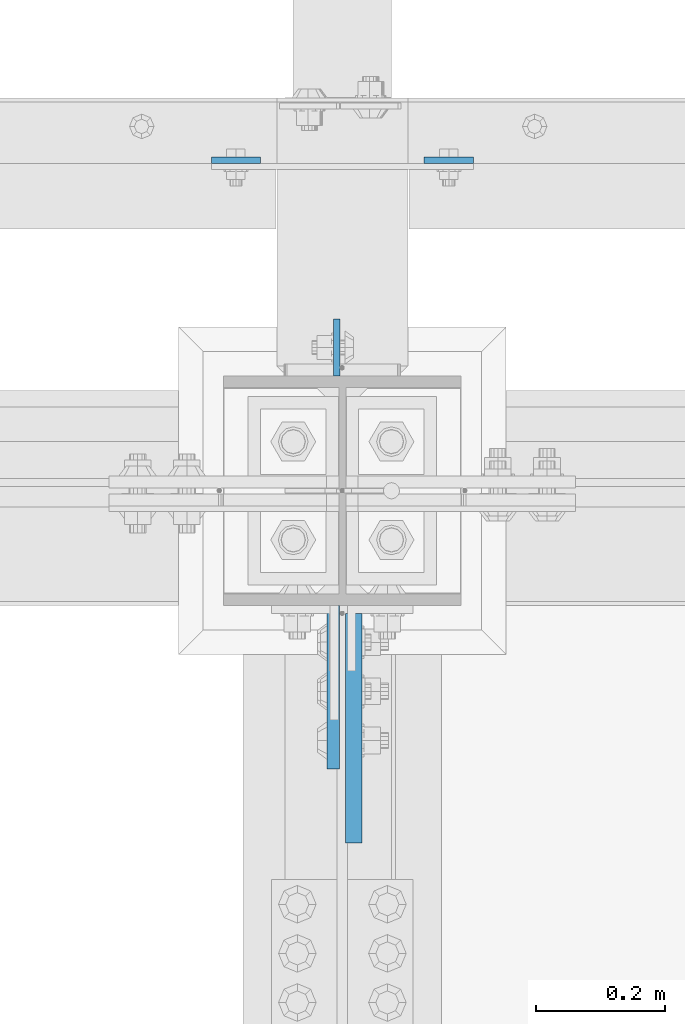
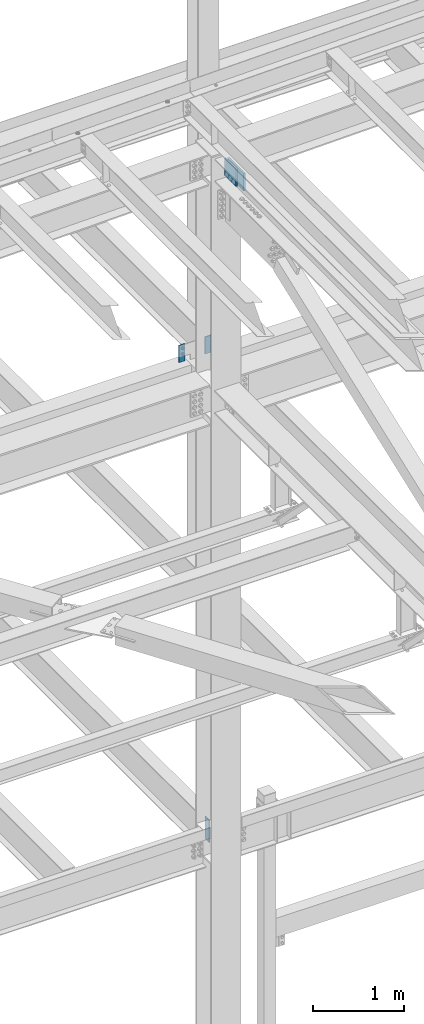
# One storey, part 1580 of 3843: 5 columns, 4 elements without a shape of their own.
"""IFC2X3 building model written with IfcOpenShell, lengths in millimetres."""

from ifc_helpers import new_model, si_unit, frame, origin_with_axes, place, context, subcontext, project, spatial, faceted_brep, material, type_object, element, aggregate, save


model = new_model("IFC2X3")

# Units and contexts
model_context = context("Model", 3, precision=1e-05, world=origin_with_axes())
body_context = subcontext(model_context, "Body", "Model", "MODEL_VIEW")
ifc_project = project(units=[si_unit("LENGTHUNIT", "METRE", prefix="MILLI"), si_unit("AREAUNIT", "SQUARE_METRE"), si_unit("VOLUMEUNIT", "CUBIC_METRE"), si_unit("MASSUNIT", "GRAM", prefix="KILO"), si_unit("TIMEUNIT", "SECOND"), si_unit("PLANEANGLEUNIT", "RADIAN"), si_unit("SOLIDANGLEUNIT", "STERADIAN"), si_unit("THERMODYNAMICTEMPERATUREUNIT", "DEGREE_CELSIUS"), si_unit("LUMINOUSINTENSITYUNIT", "LUMEN")], contexts=[model_context])

# Site, building, storey
site_placement = place(None, origin_with_axes())
site = spatial("IfcSite", under=ifc_project, at=site_placement, CompositionType="ELEMENT")
building_placement = place(site_placement, origin_with_axes())
building = spatial("IfcBuilding", under=site, at=building_placement, Name="Undefined", CompositionType="ELEMENT")
storey_placement = place(building_placement, origin_with_axes())
storey = spatial("IfcBuildingStorey", under=building, at=storey_placement, Name="Undefined", CompositionType="ELEMENT", Elevation=0.0)

# Assembly, column
assembly_1_placement = place(storey_placement, origin_with_axes())
assembly_1 = element("IfcElementAssembly", 1, at=assembly_1_placement, inside=storey, Name="GIRT", AssemblyPlace="NOTDEFINED", PredefinedType="RIGID_FRAME")
ifc_material = material(Name="STEEL/A572-50")
column_type_1 = type_object("IfcColumnType", PredefinedType="NOTDEFINED")
column_1_placement = place(assembly_1_placement, frame((41897.3, 92727.4625, 42367.2), z_axis=(-1.0, 0.0, 0.0), x_axis=(0.0, 0.0, 1.0)))
column_1 = element("IfcColumn", 2, at=column_1_placement, type_object=column_type_1, material=ifc_material, Name="PLATE", context=body_context, shape_type="Brep", body=[
    faceted_brep([(0.0, 4.76250000000073, -38.0999999999985), (0.0, 4.76250000000073, 38.0999999999985), (228.599999999999, 4.76249999999709, 38.1000000000058), (228.599999999999, 4.76249999999709, -38.1000000000058), (0.0, -4.76250000000073, 38.0999999999985), (228.599999999999, -4.76249999999709, 38.1000000000058), (0.0, -4.76250000000073, -38.0999999999985), (228.599999999999, -4.76249999999709, -38.1000000000058)], [[[0, 1, 2, 3]], [[1, 4, 5, 2]], [[4, 6, 7, 5]], [[6, 0, 3, 7]], [[5, 7, 3, 2]], [[6, 4, 1, 0]]]),
])
aggregate(assembly_1, [column_1])

assembly_2_placement = place(storey_placement, origin_with_axes())
assembly_2 = element("IfcElementAssembly", 3, at=assembly_2_placement, inside=storey, Name="GIRT", AssemblyPlace="NOTDEFINED", PredefinedType="RIGID_FRAME")
column_2_placement = place(assembly_2_placement, frame((42227.5, 92727.4625, 42367.2), z_axis=(-1.0, 0.0, 0.0), x_axis=(0.0, 0.0, 1.0)))
column_2 = element("IfcColumn", 4, at=column_2_placement, type_object=column_type_1, material=ifc_material, Name="PLATE", context=body_context, shape_type="Brep", body=[
    faceted_brep([(0.0, 4.76250000000073, -38.0999999999985), (0.0, 4.76250000000073, 38.0999999999985), (228.599999999999, 4.76249999999709, 38.1000000000058), (228.599999999999, 4.76249999999709, -38.1000000000058), (0.0, -4.76250000000073, 38.0999999999985), (228.599999999999, -4.76249999999709, 38.1000000000058), (0.0, -4.76250000000073, -38.0999999999985), (228.599999999999, -4.76249999999709, -38.1000000000058)], [[[0, 1, 2, 3]], [[1, 4, 5, 2]], [[4, 6, 7, 5]], [[6, 0, 3, 7]], [[5, 7, 3, 2]], [[6, 4, 1, 0]]]),
])
aggregate(assembly_2, [column_2])

# Assembly, columns
assembly_3_placement = place(storey_placement, origin_with_axes())
assembly_3 = element("IfcElementAssembly", 5, at=assembly_3_placement, inside=storey, Name="COLUMN", AssemblyPlace="NOTDEFINED", PredefinedType="RIGID_FRAME")
column_type_2 = type_object("IfcColumnType", PredefinedType="NOTDEFINED")
column_3_placement = place(assembly_3_placement, frame((42053.66875, 92436.95, 36093.4), z_axis=(0.0, -1.0, 0.0), x_axis=(0.0, 0.0, 1.0)))
column_3 = element("IfcColumn", 6, at=column_3_placement, type_object=column_type_2, material=ifc_material, Name="PLATE", context=body_context, shape_type="Brep", body=[
    faceted_brep([(0.0, 4.76249999999709, -44.4500000000007), (0.0, 4.76249999999709, 44.4500000000007), (304.799999999996, 4.76249999999709, 44.4500000000007), (304.799999999996, 4.76249999999709, -44.4500000000007), (0.0, -4.76249999999709, 44.4500000000007), (304.799999999996, -4.76249999999709, 44.4500000000007), (0.0, -4.76249999999709, -44.4500000000007), (304.799999999996, -4.76249999999709, -44.4500000000007)], [[[0, 1, 2, 3]], [[1, 4, 5, 2]], [[4, 6, 7, 5]], [[6, 0, 3, 7]], [[5, 7, 3, 2]], [[6, 4, 1, 0]]]),
])
column_type_3 = type_object("IfcColumnType", PredefinedType="NOTDEFINED")
column_4_placement = place(assembly_3_placement, frame((42048.1125713779, 91909.9, 45225.9008418066), z_axis=(0.0, 1.0, 0.0), x_axis=(0.0, 0.0, 1.0)))
column_4 = element("IfcColumn", 7, at=column_4_placement, type_object=column_type_3, material=ifc_material, Name="PLATE", context=body_context, shape_type="Brep", body=[
    faceted_brep([(0.0, 9.52499999999418, -127.0), (0.0, 9.52499999999418, 127.0), (228.599999999999, 9.52499999999418, 127.0), (228.599999999999, 9.52499999999418, -127.0), (0.0, -9.52499999999418, 127.0), (228.599999999999, -9.52499999999418, 127.0), (0.0, -9.52499999999418, -127.0), (228.599999999999, -9.52499999999418, -127.0)], [[[0, 1, 2, 3]], [[1, 4, 5, 2]], [[4, 6, 7, 5]], [[6, 0, 3, 7]], [[5, 7, 3, 2]], [[6, 4, 1, 0]]]),
])
aggregate(assembly_3, [column_4, column_3])

# Assembly, column
assembly_4_placement = place(storey_placement, origin_with_axes())
assembly_4 = element("IfcElementAssembly", 8, at=assembly_4_placement, inside=storey, Name="BEAM", AssemblyPlace="NOTDEFINED", PredefinedType="RIGID_FRAME")
column_type_4 = type_object("IfcColumnType", PredefinedType="NOTDEFINED")
column_5_placement = place(assembly_4_placement, frame((42079.8625000339, 91846.4, 45225.9008418066), z_axis=(0.0, 1.0, 0.0), x_axis=(0.0, 0.0, 1.0)))
column_5 = element("IfcColumn", 9, at=column_5_placement, type_object=column_type_4, material=ifc_material, Name="PLATE", context=body_context, shape_type="Brep", body=[
    faceted_brep([(-1.45519152283669e-11, 12.7000000000025, -177.800000000003), (-1.45519152283669e-11, 12.7000000000025, 177.800000000003), (228.600000000013, 12.6999999999971, 177.799999999999), (228.600000000013, 12.6999999999971, -177.799999999999), (4.36557456851006e-11, -12.7000000000171, 177.800000000003), (228.600000000013, -12.6999999999971, 177.799999999999), (4.36557456851006e-11, -12.7000000000171, -177.800000000003), (228.600000000013, -12.6999999999971, -177.799999999999)], [[[0, 1, 2, 3]], [[1, 4, 5, 2]], [[4, 6, 7, 5]], [[6, 0, 3, 7]], [[5, 7, 3, 2]], [[6, 4, 1, 0]]]),
])
aggregate(assembly_4, [column_5])

save(model, "model.ifc")
